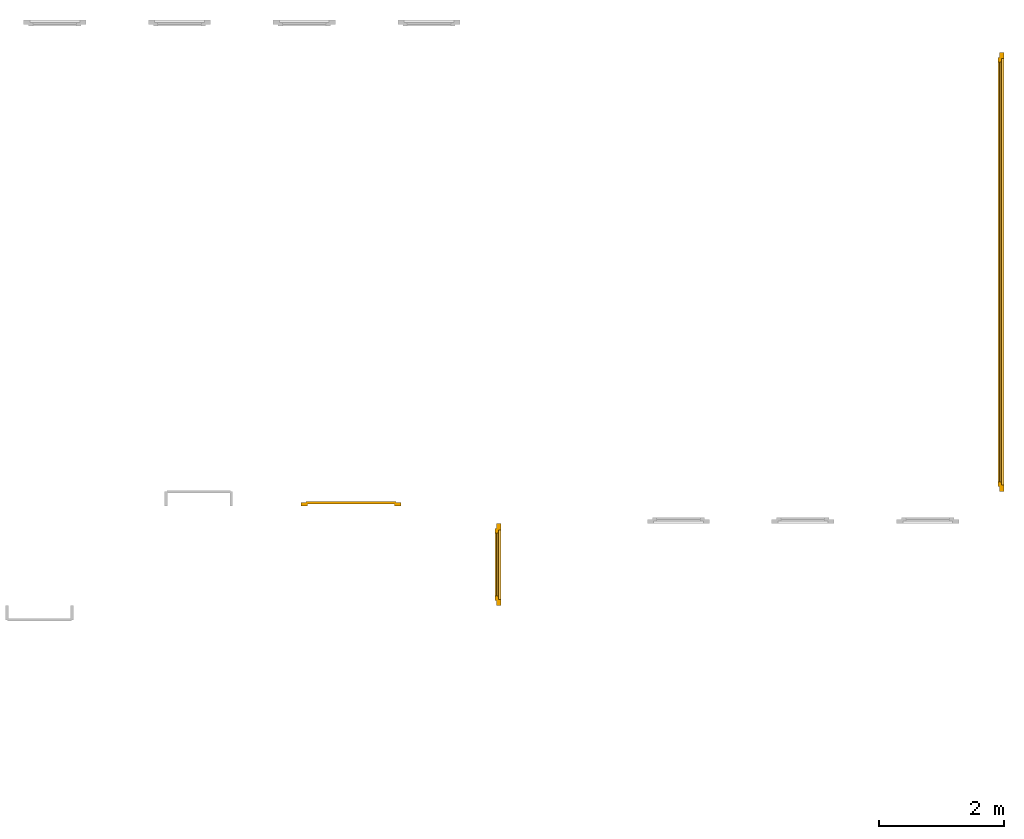
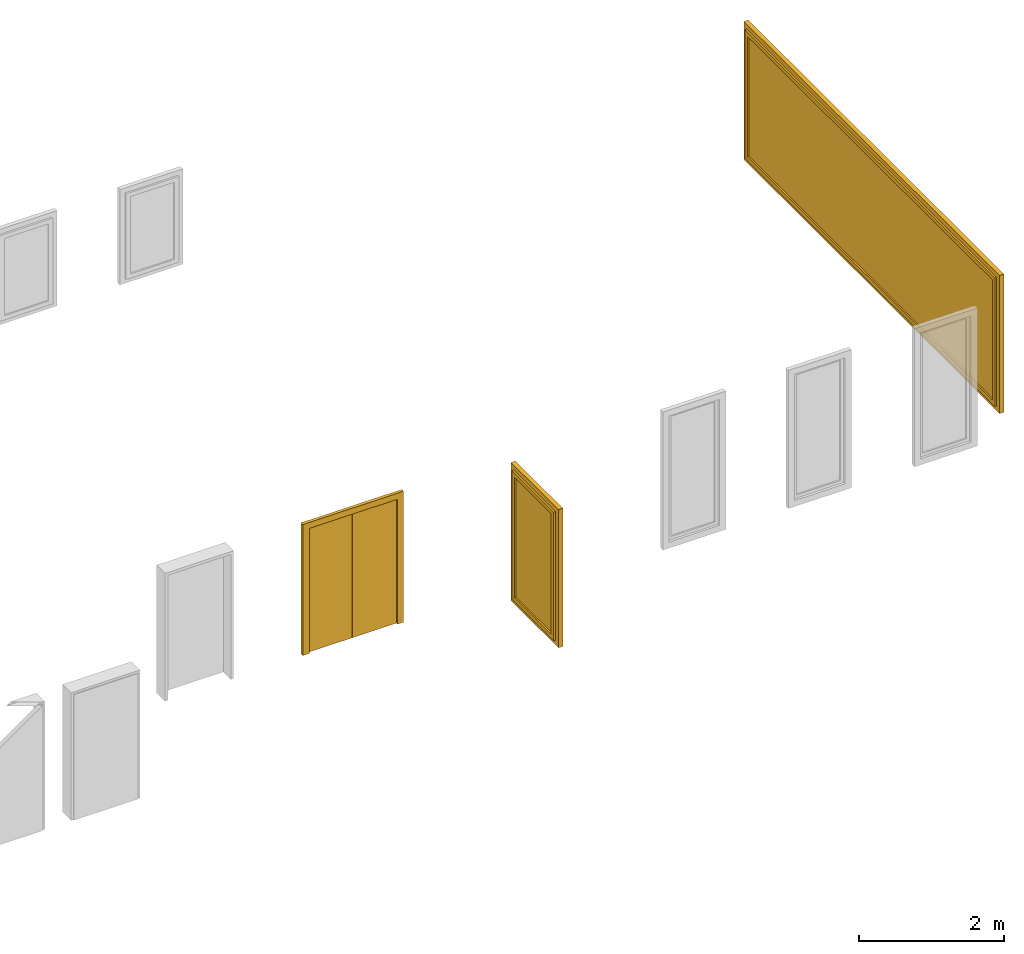
# One storey, part 5 of 5: 2 windows, 1 door.
"""IFC4 building model written with IfcOpenShell, lengths in metres."""

import ifcopenshell
import ifcopenshell.guid

model = None  # the IFC model being written
_history = None  # IfcOwnerHistory: only IFC2X3 demands one
_inside = {}  # id of a spatial element -> (the spatial element, [elements in it])
_under = {}  # id of a project, library or spatial element -> (it, [spatial elements below it])
_declared = {}  # id of a project -> (the project, [libraries it declares])
_typed = {}  # id of a type object -> (the type object, [elements of that type])
_made_of = {}  # id of a material, layer set ... -> (it, [elements and type objects made of it])


def new_model(schema):
    """Start an empty IFC model of exactly this schema.

    Asked for "IFC4X3", IfcOpenShell would pick the latest addendum, in which some entities
    have other attributes; the version numbers below select the first issue.
    IFC2X3 requires an IfcOwnerHistory on every rooted entity: one is made here for all.
    """
    global model, _history
    if schema == "IFC4X3":
        model = ifcopenshell.file(schema_version=(4, 3, 0, 0))
    else:
        model = ifcopenshell.file(schema=schema)
    _inside.clear()
    _under.clear()
    _declared.clear()
    _typed.clear()
    _made_of.clear()
    _history = None
    if model.schema == "IFC2X3":
        org = make("IfcOrganization", Name="unknown")
        user = make(
            "IfcPersonAndOrganization",
            ThePerson=make("IfcPerson", FamilyName="unknown"),
            TheOrganization=org,
        )
        app = make(
            "IfcApplication",
            ApplicationDeveloper=org,
            Version="unknown",
            ApplicationFullName="unknown",
            ApplicationIdentifier="unknown",
        )
        _history = make(
            "IfcOwnerHistory",
            OwningUser=user,
            OwningApplication=app,
            ChangeAction="ADDED",
            CreationDate=0,
        )
    return model


def make(cls, **values):
    """One entity of the class cls with the attributes given. An attribute that is None is left unset."""
    return model.create_entity(
        cls, **{name: value for name, value in values.items() if value is not None}
    )


def entity(cls, *values):
    """Any entity or typed value of the class cls, its attributes in the order of the schema. None: left unset."""
    e = model.create_entity(cls)
    for i, value in enumerate(values):
        if value is not None:
            e[i] = value
    return e


def rooted(cls, **values):
    """An entity with a GlobalId (a new one), such as an element, a storey or a relation."""
    return make(cls, GlobalId=ifcopenshell.guid.new(), OwnerHistory=_history, **values)


def si_unit(unit_type, name, prefix=None):
    """IfcSIUnit, for example si_unit("LENGTHUNIT", "METRE", prefix="MILLI")."""
    return make("IfcSIUnit", UnitType=unit_type, Prefix=prefix, Name=name)


def converted_unit(unit_type, name, factor, base, dimensions=None, offset=None):
    """IfcConversionBasedUnit, such as the inch: factor (a typed value) times the base unit."""
    return make(
        "IfcConversionBasedUnit"
        if offset is None
        else "IfcConversionBasedUnitWithOffset",
        ConversionOffset=offset,
        Dimensions=None
        if dimensions is None
        else entity("IfcDimensionalExponents", *dimensions),
        UnitType=unit_type,
        Name=name,
        ConversionFactor=make(
            "IfcMeasureWithUnit", ValueComponent=factor, UnitComponent=base
        ),
    )


def derived_unit(unit_type, elements):
    """IfcDerivedUnit: a product of units, each with its exponent."""
    return make(
        "IfcDerivedUnit",
        Elements=[
            make("IfcDerivedUnitElement", Unit=unit, Exponent=power)
            for unit, power in elements
        ],
        UnitType=unit_type,
    )


def assignment(units):
    """IfcUnitAssignment: the units of a project."""
    return None if units is None else make("IfcUnitAssignment", Units=units)


def point(xyz):
    """IfcCartesianPoint."""
    return None if xyz is None else make("IfcCartesianPoint", Coordinates=xyz)


def direction(xyz):
    """IfcDirection."""
    return None if xyz is None else make("IfcDirection", DirectionRatios=xyz)


def frame(location, z_axis=None, x_axis=None):
    """IfcAxis2Placement3D, a coordinate frame: its origin and axes. An axis left out is left unset."""
    return make(
        "IfcAxis2Placement3D",
        Location=point(location),
        Axis=direction(z_axis),
        RefDirection=direction(x_axis),
    )


def origin_with_axes():
    """The frame at (0, 0, 0) with the z axis (0, 0, 1) and the x axis (1, 0, 0) written out."""
    return frame((0.0, 0.0, 0.0), z_axis=(0.0, 0.0, 1.0), x_axis=(1.0, 0.0, 0.0))


def place(relative_to, where):
    """IfcLocalPlacement: puts the frame where relative to a parent placement (None: the world)."""
    return make(
        "IfcLocalPlacement", PlacementRelTo=relative_to, RelativePlacement=where
    )


def context(
    kind, dimensions, precision=None, world=None, true_north=None, identifier=None
):
    """IfcGeometricRepresentationContext, for example the 3D "Model" context."""
    return make(
        "IfcGeometricRepresentationContext",
        ContextIdentifier=identifier,
        ContextType=kind,
        CoordinateSpaceDimension=dimensions,
        Precision=precision,
        WorldCoordinateSystem=world,
        TrueNorth=true_north,
    )


def subcontext(parent, identifier, kind, view, scale=None):
    """IfcGeometricRepresentationSubContext, for example "Body" below "Model"."""
    return make(
        "IfcGeometricRepresentationSubContext",
        ContextIdentifier=identifier,
        ContextType=kind,
        ParentContext=parent,
        TargetScale=scale,
        TargetView=view,
    )


def project(units=None, contexts=None):
    """IfcProject with its units and contexts."""
    return rooted(
        "IfcProject",
        Name="project",
        RepresentationContexts=contexts,
        UnitsInContext=assignment(units),
    )


def spatial(cls, under=None, at=None, **own):
    """A site, building, storey or space (cls), placed at a placement, below another one or the project."""
    s = rooted(cls, ObjectPlacement=at, **own)
    if under is not None:
        _under.setdefault(under.id(), (under, []))[1].append(s)
    return s


def point_list(points):
    """IfcCartesianPointList2D or 3D."""
    cls = (
        "IfcCartesianPointList2D" if len(points[0]) == 2 else "IfcCartesianPointList3D"
    )
    return make(cls, CoordList=points)


def polygons(points, faces, closed=None, point_numbers=None):
    """IfcPolygonalFaceSet: a face is its outer loop, then its inner loops; points numbered from 1."""
    made = []
    for loops in faces:
        if len(loops) == 1:
            made.append(make("IfcIndexedPolygonalFace", CoordIndex=loops[0]))
        else:
            made.append(
                make(
                    "IfcIndexedPolygonalFaceWithVoids",
                    CoordIndex=loops[0],
                    InnerCoordIndices=loops[1:],
                )
            )
    return make(
        "IfcPolygonalFaceSet",
        Coordinates=point_list(points),
        Closed=closed,
        Faces=made,
        PnIndex=point_numbers,
    )


def shape(context_of_items, identifier, shape_type, items):
    """IfcShapeRepresentation: the items that make up one representation, for example the "Body"."""
    return make(
        "IfcShapeRepresentation",
        ContextOfItems=context_of_items,
        RepresentationIdentifier=identifier,
        RepresentationType=shape_type,
        Items=items,
    )


def made_of(thing, what):
    """Note that an element or type object is made of a material, layer set ...; save() writes the relation."""
    if what is not None:
        _made_of.setdefault(what.id(), (what, []))[1].append(thing)
    return thing


def type_object(cls, material=None, **own):
    """A type object (cls), such as IfcWallType, which elements share."""
    return made_of(rooted(cls, **own), material)


def element(
    cls,
    number,
    at=None,
    inside=None,
    cuts=None,
    type_object=None,
    material=None,
    context=None,
    identifier="Body",
    shape_type=None,
    held_by="IfcProductDefinitionShape",
    body=None,
    shapes=None,
    **own,
):
    """One element of the class cls, such as IfcWall. Its Tag is "e" and its number.

    at: its placement. inside: the storey or other place that contains it. cuts: it is an
    opening in that element (IfcRelVoidsElement). A single representation is given by context,
    identifier, shape_type and body (its items); several are given by shapes. held_by: the class
    of the entity that holds the representations. save() writes the other relations.
    """
    e = rooted(cls, Tag="e%d" % number, ObjectPlacement=at, **own)
    if body is not None:
        shapes = [shape(context, identifier, shape_type, body)]
    if shapes is not None:
        e.Representation = make(held_by, Representations=shapes)
    if inside is not None:
        _inside.setdefault(inside.id(), (inside, []))[1].append(e)
    if cuts is not None:
        rooted(
            "IfcRelVoidsElement", RelatingBuildingElement=cuts, RelatedOpeningElement=e
        )
    if type_object is not None:
        _typed.setdefault(type_object.id(), (type_object, []))[1].append(e)
    return made_of(e, material)


def aggregate(whole, parts):
    """IfcRelAggregates: a whole, such as a stair, and the parts it consists of."""
    return rooted("IfcRelAggregates", RelatingObject=whole, RelatedObjects=parts)


def save(model, path):
    """Write the relations noted so far, then the file.

    IfcRelAggregates (storeys below a building ...), IfcRelContainedInSpatialStructure (elements
    in a storey), IfcRelDefinesByType, IfcRelAssociatesMaterial and IfcRelDeclares: one each for
    every whole, place, type object, material and project.
    """
    for whole, parts in _under.values():
        aggregate(whole, parts)
    for where, things in _inside.values():
        rooted(
            "IfcRelContainedInSpatialStructure",
            RelatedElements=things,
            RelatingStructure=where,
        )
    for kind, things in _typed.values():
        rooted("IfcRelDefinesByType", RelatedObjects=things, RelatingType=kind)
    for what, things in _made_of.values():
        rooted("IfcRelAssociatesMaterial", RelatedObjects=things, RelatingMaterial=what)
    for by, libraries in _declared.values():
        rooted("IfcRelDeclares", RelatingContext=by, RelatedDefinitions=libraries)
    model.write(path)


model = new_model("IFC4")

# Units and contexts
model_context = context("Model", 3, precision=1e-05, world=origin_with_axes(), true_north=direction((0.0, 1.0)))
body_context = subcontext(model_context, "Body", "Model", "MODEL_VIEW")
ifc_project = project(units=[si_unit("LENGTHUNIT", "METRE"), si_unit("AREAUNIT", "SQUARE_METRE"), si_unit("VOLUMEUNIT", "CUBIC_METRE"), converted_unit("PLANEANGLEUNIT", "DEGREE", entity("IfcPlaneAngleMeasure", 0.0174532925199433), si_unit("PLANEANGLEUNIT", "RADIAN"), dimensions=[0, 0, 0, 0, 0, 0, 0]), converted_unit("TIMEUNIT", "Year", entity("IfcTimeMeasure", 31557600.0), si_unit("TIMEUNIT", "SECOND"), dimensions=[0, 0, 1, 0, 0, 0, 0]), si_unit("MASSUNIT", "GRAM", prefix="KILO"), si_unit("THERMODYNAMICTEMPERATUREUNIT", "DEGREE_CELSIUS"), si_unit("LUMINOUSINTENSITYUNIT", "LUMEN"), si_unit("ENERGYUNIT", "JOULE", prefix="MEGA"), derived_unit("THERMALCONDUCTANCEUNIT", [(si_unit("POWERUNIT", "WATT"), 1), (si_unit("LENGTHUNIT", "METRE"), -1), (si_unit("THERMODYNAMICTEMPERATUREUNIT", "KELVIN"), -1)]), derived_unit("SPECIFICHEATCAPACITYUNIT", [(si_unit("ENERGYUNIT", "JOULE"), 1), (si_unit("MASSUNIT", "GRAM", prefix="KILO"), -1), (si_unit("THERMODYNAMICTEMPERATUREUNIT", "KELVIN"), -1)]), derived_unit("MASSDENSITYUNIT", [(si_unit("MASSUNIT", "GRAM", prefix="KILO"), 1), (si_unit("VOLUMEUNIT", "CUBIC_METRE"), -1)])], contexts=[model_context])

# Site, building, storey
site_placement = place(None, origin_with_axes())
site = spatial("IfcSite", under=ifc_project, at=site_placement, CompositionType="ELEMENT")
building_placement = place(None, origin_with_axes())
building = spatial("IfcBuilding", under=site, at=building_placement, CompositionType="ELEMENT")
storey_placement = place(None, frame((0.0, 0.0, 7.5), z_axis=(0.0, 0.0, 1.0), x_axis=(1.0, 0.0, 0.0)))
storey = spatial("IfcBuildingStorey", under=building, at=storey_placement, Name="2 OG", CompositionType="ELEMENT", Elevation=7.5)

# Windows
window_type = type_object("IfcWindowType", Name="1-27", PartitioningType="SINGLE_PANEL", PredefinedType="WINDOW")
window_1_placement = place(None, frame((52.38, 5.45499994546755, 7.5), z_axis=(0.0, 0.0, 1.0), x_axis=(0.0, 1.0, 0.0)))
element("IfcWindow", 1, at=window_1_placement, inside=storey, type_object=window_type, Name="Fenster-001", OverallHeight=2.32, OverallWidth=1.3125, context=body_context, shape_type="Tessellation", body=[
    polygons([(1.3125, 0.0, 0.0), (1.2125, 0.0, 0.0999999999999996), (1.2125, 0.0700000000000003, 0.0999999999999996), (1.3125, 0.0700000000000003, 0.0), (1.3125, 0.0, 2.32), (1.2125, 0.0, 2.22), (1.2125, 0.0700000000000003, 2.22), (1.3125, 0.0700000000000003, 2.32)], [[[1, 2, 3, 4]], [[1, 5, 6, 2]], [[2, 6, 7, 3]], [[4, 3, 7, 8]], [[5, 1, 4, 8]], [[6, 5, 8, 7]]], closed=True),
    polygons([(0.0, 0.0, 0.0), (0.0, 0.0, 2.32), (0.0, 0.0700000000000003, 2.32), (0.0, 0.0700000000000003, 0.0), (0.0999999999999996, 0.0, 0.0999999999999996), (0.0999999999999996, 0.0, 2.22), (0.0999999999999996, 0.0700000000000003, 2.22), (0.0999999999999996, 0.0700000000000003, 0.0999999999999996)], [[[1, 2, 3, 4]], [[1, 5, 6, 2]], [[2, 6, 7, 3]], [[4, 3, 7, 8]], [[5, 1, 4, 8]], [[6, 5, 8, 7]]], closed=True),
    polygons([(1.3125, 0.0, 0.0), (0.0, 0.0, 0.0), (0.0, 0.0700000000000003, 0.0), (1.3125, 0.0700000000000003, 0.0), (1.2125, 0.0, 0.0999999999999996), (0.656250000000001, 0.0, 0.0999999999999996), (0.0999999999999996, 0.0, 0.0999999999999996), (0.0999999999999996, 0.0700000000000003, 0.0999999999999996), (0.656250000000001, 0.0700000000000003, 0.0999999999999996), (1.2125, 0.0700000000000003, 0.0999999999999996)], [[[1, 2, 3, 4]], [[1, 5, 6, 7, 2]], [[2, 7, 8, 3]], [[4, 3, 8, 9, 10]], [[5, 1, 4, 10]], [[6, 5, 10, 9]], [[7, 6, 9, 8]]], closed=True),
    polygons([(1.3125, 0.0, 2.32), (1.2125, 0.0, 2.22), (1.2125, 0.0700000000000003, 2.22), (1.3125, 0.0700000000000003, 2.32), (0.0, 0.0, 2.32), (0.0999999999999996, 0.0, 2.22), (0.656250000000001, 0.0, 2.22), (0.656250000000001, 0.0700000000000003, 2.22), (0.0999999999999996, 0.0700000000000003, 2.22), (0.0, 0.0700000000000003, 2.32)], [[[1, 2, 3, 4]], [[1, 5, 6, 7, 2]], [[2, 7, 8, 3]], [[4, 3, 8, 9, 10]], [[5, 1, 4, 10]], [[6, 5, 10, 9]], [[7, 6, 9, 8]]], closed=True),
    polygons([(1.2325, 0.0700000000000003, 0.0800000000000001), (1.1625, 0.0700000000000003, 0.15), (1.1625, 0.100000000000001, 0.15), (1.2325, 0.100000000000001, 0.0800000000000001), (1.2325, 0.0700000000000003, 2.24), (1.1625, 0.0700000000000003, 2.17), (1.1625, 0.100000000000001, 2.17), (1.2325, 0.100000000000001, 2.24)], [[[1, 2, 3, 4]], [[1, 5, 6, 2]], [[2, 6, 7, 3]], [[4, 3, 7, 8]], [[5, 1, 4, 8]], [[6, 5, 8, 7]]], closed=True),
    polygons([(0.0800000000000001, 0.0700000000000003, 0.0800000000000001), (0.0800000000000001, 0.100000000000001, 0.0800000000000001), (0.15, 0.100000000000001, 0.15), (0.15, 0.0700000000000003, 0.15), (0.0800000000000001, 0.0700000000000003, 2.24), (0.0800000000000001, 0.100000000000001, 2.24), (0.15, 0.100000000000001, 2.17), (0.15, 0.0700000000000003, 2.17)], [[[1, 2, 3, 4]], [[5, 6, 2, 1]], [[2, 6, 7, 3]], [[4, 3, 7, 8]], [[1, 4, 8, 5]], [[8, 7, 6, 5]]], closed=True),
    polygons([(1.2325, 0.0700000000000003, 0.0800000000000001), (0.0800000000000001, 0.0700000000000003, 0.0800000000000001), (0.0800000000000001, 0.100000000000001, 0.0800000000000001), (1.2325, 0.100000000000001, 0.0800000000000001), (1.1625, 0.0700000000000003, 0.15), (0.15, 0.0700000000000003, 0.15), (0.15, 0.100000000000001, 0.15), (1.1625, 0.100000000000001, 0.15)], [[[1, 2, 3, 4]], [[1, 5, 6, 2]], [[2, 6, 7, 3]], [[4, 3, 7, 8]], [[5, 1, 4, 8]], [[6, 5, 8, 7]]], closed=True),
    polygons([(1.2325, 0.0700000000000003, 2.24), (1.2325, 0.100000000000001, 2.24), (0.0800000000000001, 0.100000000000001, 2.24), (0.0800000000000001, 0.0700000000000003, 2.24), (1.1625, 0.0700000000000003, 2.17), (1.1625, 0.100000000000001, 2.17), (0.15, 0.100000000000001, 2.17), (0.15, 0.0700000000000003, 2.17)], [[[1, 2, 3, 4]], [[5, 6, 2, 1]], [[2, 6, 7, 3]], [[4, 3, 7, 8]], [[1, 4, 8, 5]], [[8, 7, 6, 5]]], closed=True),
    polygons([(1.2125, 0.0399999999999991, 0.0999999999999996), (1.1625, 0.0399999999999991, 0.15), (1.1625, 0.0700000000000003, 0.15), (1.2125, 0.0700000000000003, 0.0999999999999996), (1.2125, 0.0399999999999991, 2.22), (1.1625, 0.0399999999999991, 2.17), (1.1625, 0.0700000000000003, 2.17), (1.2125, 0.0700000000000003, 2.22)], [[[1, 2, 3, 4]], [[1, 5, 6, 2]], [[2, 6, 7, 3]], [[4, 3, 7, 8]], [[5, 1, 4, 8]], [[6, 5, 8, 7]]], closed=True),
    polygons([(0.100000000000001, 0.0399999999999991, 0.0999999999999996), (0.100000000000001, 0.0700000000000003, 0.0999999999999996), (0.15, 0.0700000000000003, 0.15), (0.15, 0.0399999999999991, 0.15), (0.100000000000001, 0.0399999999999991, 2.22), (0.100000000000001, 0.0700000000000003, 2.22), (0.15, 0.0700000000000003, 2.17), (0.15, 0.0399999999999991, 2.17)], [[[1, 2, 3, 4]], [[5, 6, 2, 1]], [[2, 6, 7, 3]], [[4, 3, 7, 8]], [[1, 4, 8, 5]], [[8, 7, 6, 5]]], closed=True),
    polygons([(1.2125, 0.0399999999999991, 0.0999999999999996), (0.100000000000001, 0.0399999999999991, 0.0999999999999996), (0.100000000000001, 0.0700000000000003, 0.0999999999999996), (1.2125, 0.0700000000000003, 0.0999999999999996), (1.1625, 0.0399999999999991, 0.15), (0.15, 0.0399999999999991, 0.15), (0.15, 0.0700000000000003, 0.15), (1.1625, 0.0700000000000003, 0.15)], [[[1, 2, 3, 4]], [[1, 5, 6, 2]], [[2, 6, 7, 3]], [[4, 3, 7, 8]], [[5, 1, 4, 8]], [[6, 5, 8, 7]]], closed=True),
    polygons([(1.2125, 0.0399999999999991, 2.22), (1.2125, 0.0700000000000003, 2.22), (0.100000000000001, 0.0700000000000003, 2.22), (0.100000000000001, 0.0399999999999991, 2.22), (1.1625, 0.0399999999999991, 2.17), (1.1625, 0.0700000000000003, 2.17), (0.15, 0.0700000000000003, 2.17), (0.15, 0.0399999999999991, 2.17)], [[[1, 2, 3, 4]], [[5, 6, 2, 1]], [[2, 6, 7, 3]], [[4, 3, 7, 8]], [[1, 4, 8, 5]], [[8, 7, 6, 5]]], closed=True),
    polygons([(1.1625, 0.0649999999999977, 0.15), (0.15, 0.0649999999999977, 0.15), (0.15, 0.0750000000000028, 0.15), (1.1625, 0.0750000000000028, 0.15), (1.1625, 0.0649999999999977, 2.17), (0.15, 0.0649999999999977, 2.17), (0.15, 0.0750000000000028, 2.17), (1.1625, 0.0750000000000028, 2.17)], [[[1, 2, 3, 4]], [[1, 5, 6, 2]], [[2, 6, 7, 3]], [[4, 3, 7, 8]], [[5, 1, 4, 8]], [[6, 5, 8, 7]]], closed=True),
])
window_2_placement = place(None, frame((60.446, 7.28749994546756, 7.5), z_axis=(0.0, 0.0, 1.0), x_axis=(0.0, 1.0, 0.0)))
element("IfcWindow", 2, at=window_2_placement, inside=storey, type_object=window_type, Name="Fenster-004", OverallHeight=2.32, OverallWidth=7.0385, context=body_context, shape_type="Tessellation", body=[
    polygons([(0.0, 0.0, 0.0), (0.0, 0.0700000000000003, 0.0), (0.0999999999999996, 0.0700000000000003, 0.0999999999999996), (0.0999999999999996, 0.0, 0.0999999999999996), (0.0, 0.0, 2.32), (0.0, 0.0700000000000003, 2.32), (0.0999999999999996, 0.0700000000000003, 2.22), (0.0999999999999996, 0.0, 2.22)], [[[1, 2, 3, 4]], [[5, 6, 2, 1]], [[2, 6, 7, 3]], [[4, 3, 7, 8]], [[1, 4, 8, 5]], [[8, 7, 6, 5]]], closed=True),
    polygons([(7.03849994546756, 0.0, 0.0), (7.03849994546756, 0.0700000000000003, 0.0), (7.03849994546756, 0.0700000000000003, 2.32), (7.03849994546756, 0.0, 2.32), (6.93849994546756, 0.0, 0.0999999999999996), (6.93849994546756, 0.0700000000000003, 0.0999999999999996), (6.93849994546756, 0.0700000000000003, 2.22), (6.93849994546756, 0.0, 2.22)], [[[1, 2, 3, 4]], [[5, 6, 2, 1]], [[2, 6, 7, 3]], [[4, 3, 7, 8]], [[1, 4, 8, 5]], [[8, 7, 6, 5]]], closed=True),
    polygons([(0.0, 0.0, 0.0), (0.0, 0.0700000000000003, 0.0), (7.03849994546756, 0.0700000000000003, 0.0), (7.03849994546756, 0.0, 0.0), (0.0999999999999996, 0.0, 0.0999999999999996), (0.0999999999999996, 0.0700000000000003, 0.0999999999999996), (3.51924997273378, 0.0700000000000003, 0.0999999999999996), (6.93849994546756, 0.0700000000000003, 0.0999999999999996), (6.93849994546756, 0.0, 0.0999999999999996), (3.51924997273378, 0.0, 0.0999999999999996)], [[[1, 2, 3, 4]], [[5, 6, 2, 1]], [[2, 6, 7, 8, 3]], [[4, 3, 8, 9]], [[1, 4, 9, 10, 5]], [[10, 7, 6, 5]], [[9, 8, 7, 10]]], closed=True),
    polygons([(0.0, 0.0, 2.32), (0.0, 0.0700000000000003, 2.32), (0.0999999999999996, 0.0700000000000003, 2.22), (0.0999999999999996, 0.0, 2.22), (7.03849994546756, 0.0, 2.32), (7.03849994546756, 0.0700000000000003, 2.32), (6.93849994546756, 0.0700000000000003, 2.22), (3.51924997273378, 0.0700000000000003, 2.22), (3.51924997273378, 0.0, 2.22), (6.93849994546756, 0.0, 2.22)], [[[1, 2, 3, 4]], [[5, 6, 2, 1]], [[2, 6, 7, 8, 3]], [[4, 3, 8, 9]], [[1, 4, 9, 10, 5]], [[10, 7, 6, 5]], [[9, 8, 7, 10]]], closed=True),
    polygons([(0.0800000000000001, 0.0700000000000003, 0.0800000000000001), (0.0800000000000001, 0.100000000000001, 0.0800000000000001), (0.15, 0.100000000000001, 0.15), (0.15, 0.0700000000000003, 0.15), (0.0800000000000001, 0.0700000000000003, 2.24), (0.0800000000000001, 0.100000000000001, 2.24), (0.15, 0.100000000000001, 2.17), (0.15, 0.0700000000000003, 2.17)], [[[1, 2, 3, 4]], [[5, 6, 2, 1]], [[2, 6, 7, 3]], [[4, 3, 7, 8]], [[1, 4, 8, 5]], [[8, 7, 6, 5]]], closed=True),
    polygons([(6.95849994546756, 0.0700000000000003, 0.0800000000000001), (6.88849994546756, 0.0700000000000003, 0.15), (6.88849994546756, 0.100000000000001, 0.15), (6.95849994546756, 0.100000000000001, 0.0800000000000001), (6.95849994546756, 0.0700000000000003, 2.24), (6.88849994546756, 0.0700000000000003, 2.17), (6.88849994546756, 0.100000000000001, 2.17), (6.95849994546756, 0.100000000000001, 2.24)], [[[1, 2, 3, 4]], [[1, 5, 6, 2]], [[2, 6, 7, 3]], [[4, 3, 7, 8]], [[5, 1, 4, 8]], [[6, 5, 8, 7]]], closed=True),
    polygons([(0.0800000000000001, 0.0700000000000003, 0.0800000000000001), (0.0800000000000001, 0.100000000000001, 0.0800000000000001), (6.95849994546756, 0.100000000000001, 0.0800000000000001), (6.95849994546756, 0.0700000000000003, 0.0800000000000001), (0.15, 0.0700000000000003, 0.15), (0.15, 0.100000000000001, 0.15), (6.88849994546756, 0.100000000000001, 0.15), (6.88849994546756, 0.0700000000000003, 0.15)], [[[1, 2, 3, 4]], [[5, 6, 2, 1]], [[2, 6, 7, 3]], [[4, 3, 7, 8]], [[1, 4, 8, 5]], [[8, 7, 6, 5]]], closed=True),
    polygons([(0.0800000000000001, 0.0700000000000003, 2.24), (6.95849994546756, 0.0700000000000003, 2.24), (6.95849994546756, 0.100000000000001, 2.24), (0.0800000000000001, 0.100000000000001, 2.24), (0.15, 0.0700000000000003, 2.17), (6.88849994546756, 0.0700000000000003, 2.17), (6.88849994546756, 0.100000000000001, 2.17), (0.15, 0.100000000000001, 2.17)], [[[1, 2, 3, 4]], [[1, 5, 6, 2]], [[2, 6, 7, 3]], [[4, 3, 7, 8]], [[5, 1, 4, 8]], [[6, 5, 8, 7]]], closed=True),
    polygons([(0.0999999999999996, 0.0399999999999991, 0.0999999999999996), (0.0999999999999996, 0.0700000000000003, 0.0999999999999996), (0.15, 0.0700000000000003, 0.15), (0.15, 0.0399999999999991, 0.15), (0.0999999999999996, 0.0399999999999991, 2.22), (0.0999999999999996, 0.0700000000000003, 2.22), (0.15, 0.0700000000000003, 2.17), (0.15, 0.0399999999999991, 2.17)], [[[1, 2, 3, 4]], [[5, 6, 2, 1]], [[2, 6, 7, 3]], [[4, 3, 7, 8]], [[1, 4, 8, 5]], [[8, 7, 6, 5]]], closed=True),
    polygons([(6.93849994546756, 0.0399999999999991, 0.0999999999999996), (6.88849994546756, 0.0399999999999991, 0.15), (6.88849994546756, 0.0700000000000003, 0.15), (6.93849994546756, 0.0700000000000003, 0.0999999999999996), (6.93849994546756, 0.0399999999999991, 2.22), (6.88849994546756, 0.0399999999999991, 2.17), (6.88849994546756, 0.0700000000000003, 2.17), (6.93849994546756, 0.0700000000000003, 2.22)], [[[1, 2, 3, 4]], [[1, 5, 6, 2]], [[2, 6, 7, 3]], [[4, 3, 7, 8]], [[5, 1, 4, 8]], [[6, 5, 8, 7]]], closed=True),
    polygons([(0.0999999999999996, 0.0399999999999991, 0.0999999999999996), (0.0999999999999996, 0.0700000000000003, 0.0999999999999996), (6.93849994546756, 0.0700000000000003, 0.0999999999999996), (6.93849994546756, 0.0399999999999991, 0.0999999999999996), (0.15, 0.0399999999999991, 0.15), (0.15, 0.0700000000000003, 0.15), (6.88849994546756, 0.0700000000000003, 0.15), (6.88849994546756, 0.0399999999999991, 0.15)], [[[1, 2, 3, 4]], [[5, 6, 2, 1]], [[2, 6, 7, 3]], [[4, 3, 7, 8]], [[1, 4, 8, 5]], [[8, 7, 6, 5]]], closed=True),
    polygons([(0.0999999999999996, 0.0399999999999991, 2.22), (6.93849994546756, 0.0399999999999991, 2.22), (6.93849994546756, 0.0700000000000003, 2.22), (0.0999999999999996, 0.0700000000000003, 2.22), (0.15, 0.0399999999999991, 2.17), (6.88849994546756, 0.0399999999999991, 2.17), (6.88849994546756, 0.0700000000000003, 2.17), (0.15, 0.0700000000000003, 2.17)], [[[1, 2, 3, 4]], [[1, 5, 6, 2]], [[2, 6, 7, 3]], [[4, 3, 7, 8]], [[5, 1, 4, 8]], [[6, 5, 8, 7]]], closed=True),
    polygons([(0.15, 0.0649999999999977, 0.15), (0.15, 0.0750000000000028, 0.15), (6.88849994546756, 0.0750000000000028, 0.15), (6.88849994546756, 0.0649999999999977, 0.15), (0.15, 0.0649999999999977, 2.17), (0.15, 0.0750000000000028, 2.17), (6.88849994546756, 0.0750000000000028, 2.17), (6.88849994546756, 0.0649999999999977, 2.17)], [[[1, 2, 3, 4]], [[5, 6, 2, 1]], [[2, 6, 7, 3]], [[4, 3, 7, 8]], [[1, 4, 8, 5]], [[8, 7, 6, 5]]], closed=True),
])

# Door
door_type = type_object("IfcDoorType", Name="2-Fl 27", OperationType="DOUBLE_DOOR_SINGLE_SWING", PredefinedType="DOOR")
door_placement = place(None, frame((49.273, 7.05499994546756, 7.5), z_axis=(0.0, 0.0, 1.0), x_axis=(1.0, 0.0, 0.0)))
element("IfcDoor", 3, at=door_placement, inside=storey, type_object=door_type, OverallHeight=2.2, OverallWidth=1.6, context=body_context, shape_type="Tessellation", body=[
    polygons([(-0.0999999999999943, 0.0, 0.0), (-0.0999999999999943, 0.0, 2.2), (-0.0999999999999943, 0.030000000000002, 2.2), (-0.0999999999999943, 0.030000000000002, 0.0), (0.0, 0.0, 0.0), (0.0, 0.0, 2.1), (0.5749, 0.0, 2.1), (0.6999, 0.0, 2.1), (1.40000000000001, 0.0, 2.1), (1.40000000000001, 0.0, 0.0), (1.5, 0.0, 0.0), (1.5, 0.0, 2.2), (1.5, 0.0300000000000029, 2.2), (1.5, 0.0300000000000029, 0.0), (1.40000000000001, 0.0300000000000029, 0.0), (1.40000000000001, 0.0300000000000029, 2.1), (0.6999, 0.030000000000002, 2.1), (0.5749, 0.030000000000002, 2.1), (0.0, 0.030000000000002, 2.1), (0.0, 0.030000000000002, 0.0)], [[[1, 2, 3, 4]], [[1, 5, 6, 7, 8, 9, 10, 11, 12, 2]], [[2, 12, 13, 3]], [[4, 3, 13, 14, 15, 16, 17, 18, 19, 20]], [[5, 1, 4, 20]], [[6, 5, 20, 19]], [[7, 6, 19, 18]], [[8, 7, 18, 17]], [[9, 8, 17, 16]], [[10, 9, 16, 15]], [[11, 10, 15, 14]], [[12, 11, 14, 13]]], closed=True),
    polygons([(-0.0999999999999943, 0.030000000000002, 0.0), (-0.0999999999999943, 0.030000000000002, 2.2), (-0.0999999999999943, 0.0500000000000016, 2.2), (-0.0999999999999943, 0.0500000000000016, 0.0), (-0.0249999999999986, 0.030000000000002, 0.0), (-0.0249999999999986, 0.030000000000002, 2.125), (0.599900000000005, 0.030000000000002, 2.125), (0.674900000000001, 0.030000000000002, 2.125), (1.425, 0.0300000000000029, 2.125), (1.425, 0.0300000000000029, 0.0), (1.5, 0.0300000000000029, 0.0), (1.5, 0.0300000000000029, 2.2), (1.5, 0.0500000000000025, 2.2), (1.5, 0.0500000000000025, 0.0), (1.425, 0.0500000000000025, 0.0), (1.425, 0.0500000000000025, 2.125), (0.674900000000001, 0.0500000000000016, 2.125), (0.599900000000005, 0.0500000000000016, 2.125), (-0.0249999999999986, 0.0500000000000016, 2.125), (-0.0249999999999986, 0.0500000000000016, 0.0)], [[[1, 2, 3, 4]], [[1, 5, 6, 7, 8, 9, 10, 11, 12, 2]], [[2, 12, 13, 3]], [[4, 3, 13, 14, 15, 16, 17, 18, 19, 20]], [[5, 1, 4, 20]], [[6, 5, 20, 19]], [[7, 6, 19, 18]], [[8, 7, 18, 17]], [[9, 8, 17, 16]], [[10, 9, 16, 15]], [[11, 10, 15, 14]], [[12, 11, 14, 13]]], closed=True),
    polygons([(-0.0249999999999986, 0.0700000000000012, 0.0), (-0.0249999999999986, 0.0700000000000021, 2.125), (0.6995, 0.0700000000000021, 2.125), (0.6995, 0.0700000000000012, 0.0), (-0.0249999999999986, 0.030000000000002, 0.0), (-0.0249999999999986, 0.030000000000002, 2.125), (0.6995, 0.030000000000002, 2.125), (0.6995, 0.030000000000002, 0.0)], [[[1, 2, 3, 4]], [[1, 5, 6, 2]], [[2, 6, 7, 3]], [[3, 7, 8, 4]], [[4, 8, 5, 1]], [[8, 7, 6, 5]]], closed=True),
    polygons([(1.425, 0.0700000000000021, 0.0), (0.700500000000005, 0.0700000000000012, 0.0), (0.700500000000005, 0.0700000000000021, 2.125), (1.425, 0.0700000000000029, 2.125), (1.425, 0.0300000000000029, 0.0), (0.700500000000005, 0.030000000000002, 0.0), (0.700500000000005, 0.030000000000002, 2.125), (1.425, 0.0300000000000029, 2.125)], [[[1, 2, 3, 4]], [[2, 1, 5, 6]], [[3, 2, 6, 7]], [[4, 3, 7, 8]], [[1, 4, 8, 5]], [[6, 5, 8, 7]]], closed=True),
])

save(model, "model.ifc")
